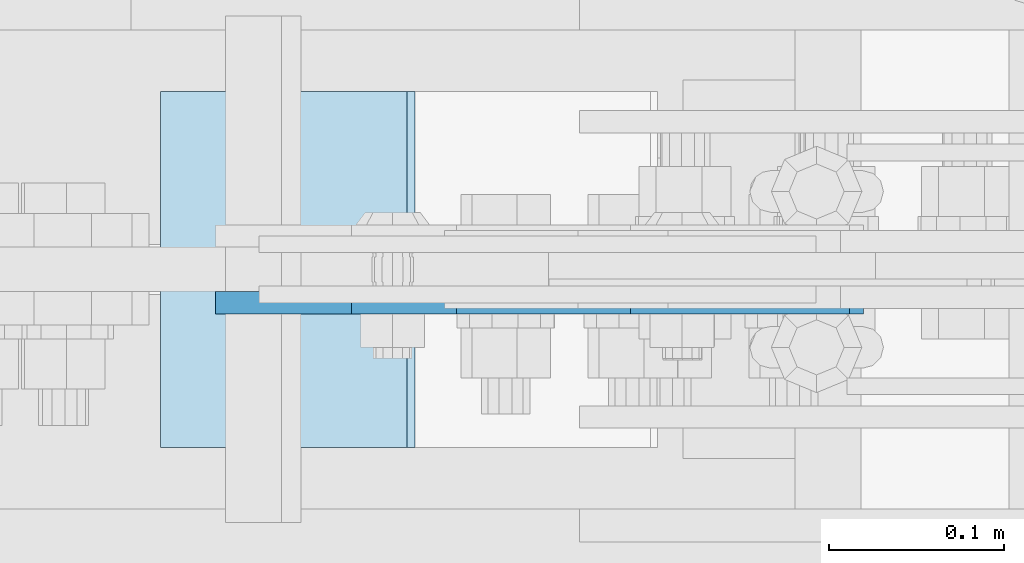
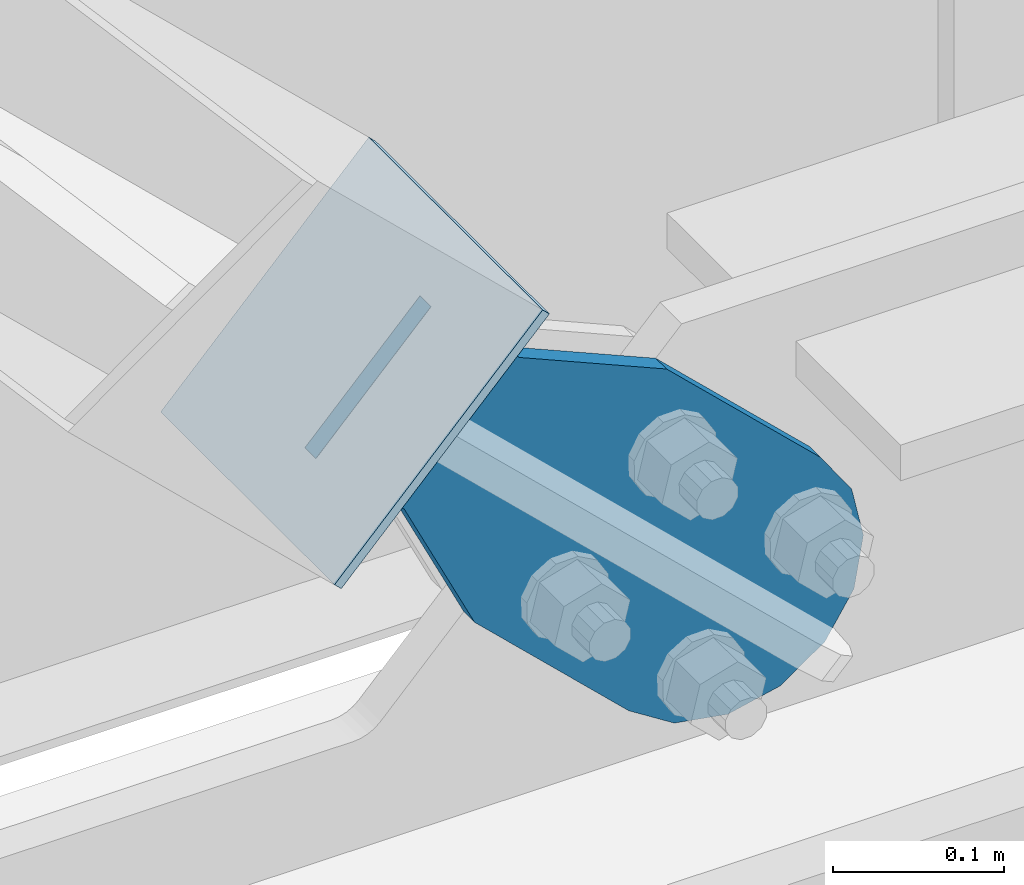
# One storey, part 1105 of 1179: 2 plates, 2 elements without a shape of their own.
"""IFC2X3 building model written with IfcOpenShell, lengths in millimetres."""

from ifc_helpers import new_model, si_unit, frame, origin_with_axes, place, context, subcontext, project, spatial, faceted_brep, material, type_object, element, aggregate, save


model = new_model("IFC2X3")

# Units and contexts
model_context = context("Model", 3, precision=1e-05, world=origin_with_axes())
body_context = subcontext(model_context, "Body", "Model", "MODEL_VIEW")
ifc_project = project(units=[si_unit("LENGTHUNIT", "METRE", prefix="MILLI"), si_unit("AREAUNIT", "SQUARE_METRE"), si_unit("VOLUMEUNIT", "CUBIC_METRE"), si_unit("MASSUNIT", "GRAM", prefix="KILO"), si_unit("TIMEUNIT", "SECOND"), si_unit("PLANEANGLEUNIT", "RADIAN"), si_unit("SOLIDANGLEUNIT", "STERADIAN"), si_unit("THERMODYNAMICTEMPERATUREUNIT", "DEGREE_CELSIUS"), si_unit("LUMINOUSINTENSITYUNIT", "LUMEN")], contexts=[model_context])

# Site, building, storey
site_placement = place(None, origin_with_axes())
site = spatial("IfcSite", under=ifc_project, at=site_placement, CompositionType="ELEMENT")
building_placement = place(site_placement, origin_with_axes())
building = spatial("IfcBuilding", under=site, at=building_placement, Name="Undefined", CompositionType="ELEMENT")
storey_placement = place(building_placement, origin_with_axes())
storey = spatial("IfcBuildingStorey", under=building, at=storey_placement, Name="Undefined", CompositionType="ELEMENT", Elevation=0.0)

# Assembly, plate
assembly_1_placement = place(storey_placement, origin_with_axes())
assembly_1 = element("IfcElementAssembly", 1, at=assembly_1_placement, inside=storey, Name="Plate", AssemblyPlace="NOTDEFINED", PredefinedType="RIGID_FRAME")
ifc_material = material(Name="STEEL/A36")
plate_type_1 = type_object("IfcPlateType", PredefinedType="NOTDEFINED")
plate_1_placement = place(assembly_1_placement, frame((15751.0008388034, 41300.4, 4364.27516093523), z_axis=(0.691222646058185, 0.0, 0.722641857060828), x_axis=(0.0, -1.0, 0.0)))
plate_1 = element("IfcPlate", 2, at=plate_1_placement, type_object=plate_type_1, material=ifc_material, Name="Plate", context=body_context, shape_type="Brep", body=[
    faceted_brep([(0.0, -3.17500000000109, 0.0), (0.0, -3.17500000000291, 203.200000000368), (0.0, 3.17499999998836, 203.200000000361), (0.0, 3.17500000000109, 7.27595761418343e-12), (203.199999999997, -3.17500000000291, 203.200000000368), (203.199999999997, 3.17499999998836, 203.200000000361), (203.199999999997, -3.17499999999927, 3.63797880709171e-12), (203.199999999997, 3.17499999999382, -3.63797880709171e-12)], [[[0, 1, 2, 3]], [[1, 4, 5, 2]], [[4, 6, 7, 5]], [[6, 0, 3, 7]], [[5, 7, 3, 2]], [[6, 4, 1, 0]]]),
])
aggregate(assembly_1, [plate_1])

assembly_2_placement = place(storey_placement, origin_with_axes())
assembly_2 = element("IfcElementAssembly", 3, at=assembly_2_placement, inside=storey, AssemblyPlace="NOTDEFINED", PredefinedType="RIGID_FRAME")
plate_type_2 = type_object("IfcPlateType", PredefinedType="NOTDEFINED")
plate_2_placement = place(assembly_2_placement, frame((15857.7070541073, 41179.75, 4480.42496888089), z_axis=(-0.691222646058184, 0.0, -0.722641857060828), x_axis=(0.722641857060828, 0.0, -0.691222646058184)))
plate_2 = element("IfcPlate", 4, at=plate_2_placement, type_object=plate_type_2, material=ifc_material, context=body_context, shape_type="Brep", body=[
    faceted_brep([(0.0, -6.34999999999854, 0.0), (-4.35647962149233e-10, -6.34999999999854, 112.184930806416), (-4.35647962149233e-10, 6.34999999999854, 112.184930806416), (0.0, 6.34999999999854, 0.0), (82.5499999996491, -6.34999999999854, 112.184930806461), (82.5499999996491, 6.34999999999854, 112.184930806461), (184.149999999618, -6.34999999999854, 149.75496540347), (184.149999999618, 6.34999999999854, 149.75496540347), (327.919242323534, -6.34999999999854, 149.754965403559), (327.919242323534, 6.34999999999854, 149.754965403559), (363.762328723451, -6.34999999999854, 142.625332233587), (363.762328723451, 6.34999999999854, 142.625332233587), (394.148630137406, -6.34999999999854, 122.321854743475), (394.148630137406, 6.34999999999854, 122.321854743475), (414.452107627645, -6.34999999999854, 91.9355533295929), (414.452107627645, 6.34999999999854, 91.9355533295929), (421.581740797776, -6.34999999999854, 56.0924638777396), (421.581740797776, 6.34999999999854, 56.0924638777396), (414.452107627878, -6.34999999999854, 20.2493774776722), (414.452107627878, 6.34999999999854, 20.2493774776722), (394.14863013775, -6.34999999999854, -10.1369239363994), (394.14863013775, 6.34999999999854, -10.1369239363994), (363.762328723789, -6.34999999999854, -30.4404014266784), (363.762328723789, 6.34999999999854, -30.4404014266784), (327.919240798041, -6.34999999999854, -37.570034596738), (327.919240798041, 6.34999999999854, -37.570034596738), (184.150000000338, -6.34999999999854, -37.5700345968289), (184.150000000338, 6.34999999999854, -37.5700345968289), (82.550000000203, -6.34999999999854, 1.2732925824821e-10), (82.550000000203, 6.34999999999854, 1.2732925824821e-10)], [[[0, 1, 2, 3]], [[1, 4, 5, 2]], [[4, 6, 7, 5]], [[6, 8, 9, 7]], [[8, 10, 11, 9]], [[10, 12, 13, 11]], [[12, 14, 15, 13]], [[14, 16, 17, 15]], [[16, 18, 19, 17]], [[18, 20, 21, 19]], [[20, 22, 23, 21]], [[22, 24, 25, 23]], [[24, 26, 27, 25]], [[26, 28, 29, 27]], [[28, 0, 3, 29]], [[5, 7, 9, 11, 13, 15, 17, 19, 21, 23, 25, 27, 29, 3, 2]], [[28, 26, 24, 22, 20, 18, 16, 14, 12, 10, 8, 6, 4, 1, 0]]]),
])
aggregate(assembly_2, [plate_2])

save(model, "model.ifc")
